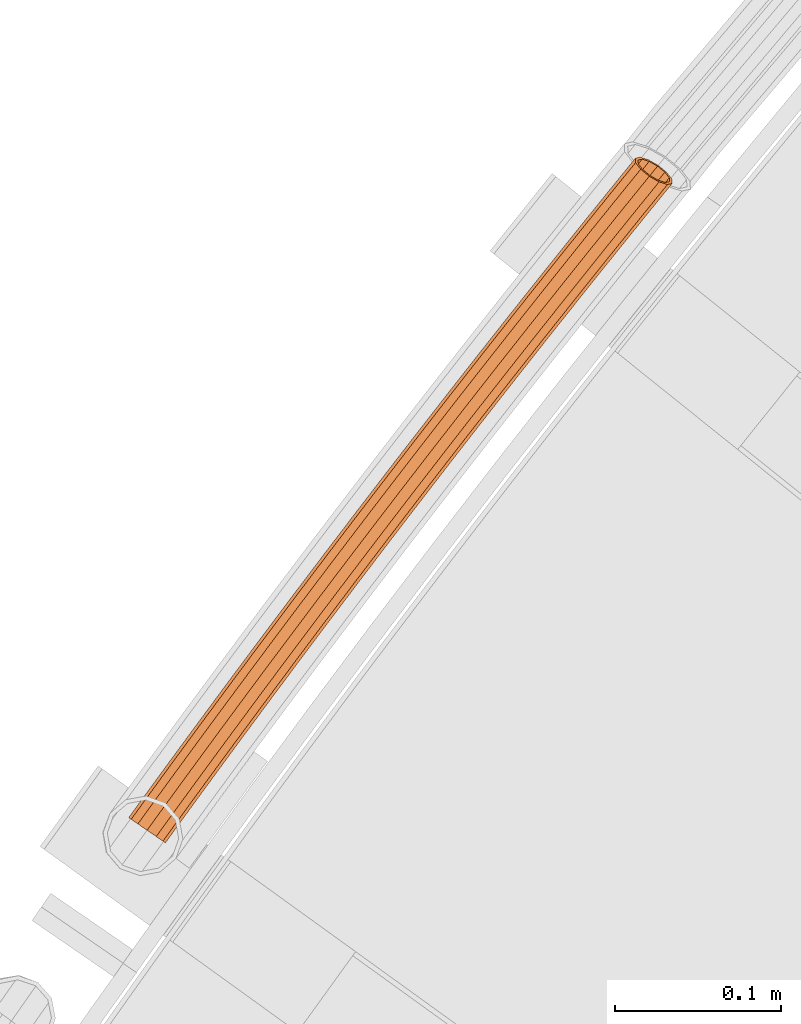
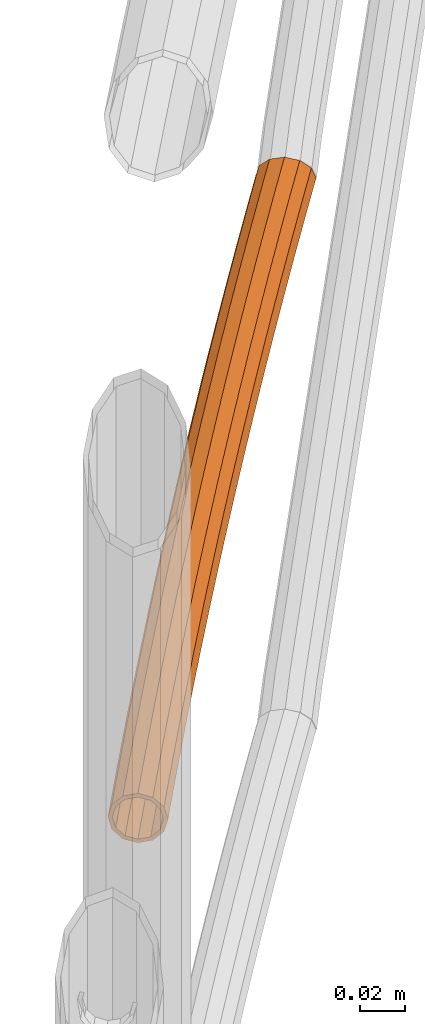
# One storey, part 66 of 126: 1 proxy.
"""IFC2X3 building model written with IfcOpenShell, lengths in millimetres."""

from ifc_helpers import new_model, si_unit, origin, origin_with_axes, place, context, project, spatial, faceted_brep, material, element, save


model = new_model("IFC2X3")

# Units and contexts
context_of_model_1 = context(None, 3, precision=0.1, world=origin())
context_of_model_2 = context(None, 3, precision=0.1, world=origin())
ifc_project = project(units=[si_unit("LENGTHUNIT", "METRE", prefix="MILLI"), si_unit("AREAUNIT", "SQUARE_METRE", prefix="CENTI"), si_unit("VOLUMEUNIT", "CUBIC_METRE", prefix="CENTI"), si_unit("MASSUNIT", "GRAM", prefix="KILO")], contexts=[context_of_model_1, context_of_model_2])

# Site, building, storey
site_placement = place(None, origin_with_axes())
site = spatial("IfcSite", under=ifc_project, at=site_placement, CompositionType="ELEMENT")
building_placement = place(site_placement, origin_with_axes())
building = spatial("IfcBuilding", under=site, at=building_placement, CompositionType="ELEMENT")
storey_placement = place(building_placement, origin_with_axes())
storey = spatial("IfcBuildingStorey", under=building, at=storey_placement, CompositionType="ELEMENT")

# Proxy
ifc_material = material(Name="S235JRG2")
proxy_placement = place(storey_placement, origin_with_axes())
element("IfcBuildingElementProxy", 1, at=proxy_placement, inside=storey, material=ifc_material, context=context_of_model_2, shape_type="Brep", body=[
    faceted_brep([(822.0705, 13221.789, 9066.8551), (823.5285, 13220.73, 9060.1301), (816.714, 13211.312, 9060.1301), (815.2283, 13212.333, 9066.8551), (827.5119, 13217.837, 9055.207), (820.7729, 13208.524, 9055.207), (832.9532, 13213.885, 9053.4051), (826.3174, 13204.714, 9053.4051), (838.3945, 13209.933, 9055.207), (831.862, 13200.905, 9055.207), (842.3779, 13207.04, 9060.1301), (835.9209, 13198.117, 9060.1301), (843.8359, 13205.981, 9066.8551), (837.4066, 13197.096, 9066.8551), (842.3779, 13207.04, 9073.5801), (835.9209, 13198.117, 9073.5801), (838.3945, 13209.933, 9078.5031), (831.862, 13200.905, 9078.5031), (832.9532, 13213.885, 9080.3051), (826.3174, 13204.714, 9080.3051), (827.5119, 13217.837, 9078.5031), (820.7729, 13208.524, 9078.5031), (823.5285, 13220.73, 9073.5801), (816.714, 13211.312, 9073.5801), (823.6888, 13220.613, 9066.8551), (824.93, 13219.712, 9072.5801), (818.142, 13210.331, 9072.5801), (816.8772, 13211.2, 9066.8551), (828.321, 13217.249, 9076.7711), (821.5973, 13207.957, 9076.7711), (832.9532, 13213.885, 9078.3051), (826.3174, 13204.714, 9078.3051), (837.5854, 13210.521, 9076.7711), (831.0375, 13201.472, 9076.7711), (840.9764, 13208.058, 9072.5801), (834.4929, 13199.098, 9072.5801), (842.2176, 13207.156, 9066.8551), (835.7576, 13198.229, 9066.8551), (840.9764, 13208.058, 9061.1301), (834.4929, 13199.098, 9061.1301), (837.5854, 13210.521, 9056.9391), (831.0375, 13201.472, 9056.9391), (832.9532, 13213.885, 9055.4051), (826.3174, 13204.714, 9055.4051), (828.321, 13217.249, 9056.9391), (821.5973, 13207.957, 9056.9391), (824.93, 13219.712, 9061.1301), (818.142, 13210.331, 9061.1301), (840.3243, 13246.83, 9066.8551), (841.7786, 13245.766, 9060.1301), (845.7518, 13242.859, 9055.207), (851.1793, 13238.888, 9053.4051), (856.6068, 13234.917, 9055.207), (860.58, 13232.01, 9060.1301), (862.0343, 13230.946, 9066.8551), (860.58, 13232.01, 9073.5801), (856.6068, 13234.917, 9078.5031), (851.1793, 13238.888, 9080.3051), (845.7518, 13242.859, 9078.5031), (841.7786, 13245.766, 9073.5801), (841.9384, 13245.649, 9066.8551), (843.1765, 13244.743, 9072.5801), (846.5589, 13242.269, 9076.7711), (851.1793, 13238.888, 9078.3051), (855.7997, 13235.508, 9076.7711), (859.1821, 13233.033, 9072.5801), (860.4202, 13232.127, 9066.8551), (859.1821, 13233.033, 9061.1301), (855.7997, 13235.508, 9056.9391), (851.1793, 13238.888, 9055.4051), (846.5589, 13242.269, 9056.9391), (843.1765, 13244.743, 9061.1301), (858.6653, 13271.807, 9066.8551), (860.1159, 13270.738, 9060.1301), (864.079, 13267.817, 9055.207), (869.4926, 13263.828, 9053.4051), (874.9062, 13259.838, 9055.207), (878.8692, 13256.917, 9060.1301), (880.3198, 13255.848, 9066.8551), (878.8692, 13256.917, 9073.5801), (874.9062, 13259.838, 9078.5031), (869.4926, 13263.828, 9080.3051), (864.079, 13267.817, 9078.5031), (860.1159, 13270.738, 9073.5801), (860.2753, 13270.621, 9066.8551), (861.5102, 13269.711, 9072.5801), (864.8839, 13267.224, 9076.7711), (869.4926, 13263.828, 9078.3051), (874.1012, 13260.431, 9076.7711), (877.4749, 13257.945, 9072.5801), (878.7098, 13257.035, 9066.8551), (877.4749, 13257.945, 9061.1301), (874.1012, 13260.431, 9056.9391), (869.4926, 13263.828, 9055.4051), (864.8839, 13267.224, 9056.9391), (861.5102, 13269.711, 9061.1301), (877.0935, 13296.721, 9066.8551), (878.5403, 13295.647, 9060.1301), (882.4931, 13292.712, 9055.207), (887.8928, 13288.703, 9053.4051), (893.2924, 13284.695, 9055.207), (897.2453, 13281.76, 9060.1301), (898.6921, 13280.686, 9066.8551), (897.2453, 13281.76, 9073.5801), (893.2924, 13284.695, 9078.5031), (887.8928, 13288.703, 9080.3051), (882.4931, 13292.712, 9078.5031), (878.5403, 13295.647, 9073.5801), (878.6993, 13295.528, 9066.8551), (879.931, 13294.614, 9072.5801), (883.296, 13292.116, 9076.7711), (887.8928, 13288.703, 9078.3051), (892.4895, 13285.291, 9076.7711), (895.8545, 13282.793, 9072.5801), (897.0862, 13281.878, 9066.8551), (895.8545, 13282.793, 9061.1301), (892.4895, 13285.291, 9056.9391), (887.8928, 13288.703, 9055.4051), (883.296, 13292.116, 9056.9391), (879.931, 13294.614, 9061.1301), (895.6084, 13321.569, 9066.8551), (897.0515, 13320.49, 9060.1301), (900.9941, 13317.542, 9055.207), (906.3797, 13313.514, 9053.4051), (911.7653, 13309.487, 9055.207), (915.7079, 13306.539, 9060.1301), (917.151, 13305.459, 9066.8551), (915.7079, 13306.539, 9073.5801), (911.7653, 13309.487, 9078.5031), (906.3797, 13313.514, 9080.3051), (900.9941, 13317.542, 9078.5031), (897.0515, 13320.49, 9073.5801), (897.2101, 13320.372, 9066.8551), (898.4386, 13319.453, 9072.5801), (901.7949, 13316.943, 9076.7711), (906.3797, 13313.514, 9078.3051), (910.9645, 13310.086, 9076.7711), (914.3208, 13307.576, 9072.5801), (915.5493, 13306.657, 9066.8551), (914.3208, 13307.576, 9061.1301), (910.9645, 13310.086, 9056.9391), (906.3797, 13313.514, 9055.4051), (901.7949, 13316.943, 9056.9391), (898.4386, 13319.453, 9061.1301), (914.21, 13346.353, 9066.8551), (915.6493, 13345.269, 9060.1301), (919.5816, 13342.307, 9055.207), (924.9531, 13338.261, 9053.4051), (930.3247, 13334.215, 9055.207), (934.2569, 13331.253, 9060.1301), (935.6962, 13330.168, 9066.8551), (934.2569, 13331.253, 9073.5801), (930.3247, 13334.215, 9078.5031), (924.9531, 13338.261, 9080.3051), (919.5816, 13342.307, 9078.5031), (915.6493, 13345.269, 9073.5801), (915.8075, 13345.15, 9066.8551), (917.0328, 13344.227, 9072.5801), (920.3803, 13341.706, 9076.7711), (924.9531, 13338.261, 9078.3051), (929.5259, 13334.816, 9076.7711), (932.8734, 13332.295, 9072.5801), (934.0987, 13331.372, 9066.8551), (932.8734, 13332.295, 9061.1301), (929.5259, 13334.816, 9056.9391), (924.9531, 13338.261, 9055.4051), (920.3803, 13341.706, 9056.9391), (917.0328, 13344.227, 9061.1301), (932.898, 13371.072, 9066.8551), (934.3336, 13369.983, 9060.1301), (938.2554, 13367.007, 9055.207), (943.6128, 13362.942, 9053.4051), (948.9702, 13358.877, 9055.207), (952.8921, 13355.902, 9060.1301), (954.3276, 13354.812, 9066.8551), (952.8921, 13355.902, 9073.5801), (948.9702, 13358.877, 9078.5031), (943.6128, 13362.942, 9080.3051), (938.2554, 13367.007, 9078.5031), (934.3336, 13369.983, 9073.5801), (934.4913, 13369.863, 9066.8551), (935.7134, 13368.936, 9072.5801), (939.0521, 13366.403, 9076.7711), (943.6128, 13362.942, 9078.3051), (948.1736, 13359.482, 9076.7711), (951.5122, 13356.949, 9072.5801), (952.7343, 13356.021, 9066.8551), (951.5122, 13356.949, 9061.1301), (948.1736, 13359.482, 9056.9391), (943.6128, 13362.942, 9055.4051), (939.0521, 13366.403, 9056.9391), (935.7134, 13368.936, 9061.1301), (951.6722, 13395.726, 9066.8551), (953.1039, 13394.632, 9060.1301), (957.0154, 13391.642, 9055.207), (962.3585, 13387.559, 9053.4051), (967.7017, 13383.475, 9055.207), (971.6132, 13380.485, 9060.1301), (973.0449, 13379.391, 9066.8551), (971.6132, 13380.485, 9073.5801), (967.7017, 13383.475, 9078.5031), (962.3585, 13387.559, 9080.3051), (957.0154, 13391.642, 9078.5031), (953.1039, 13394.632, 9073.5801), (953.2613, 13394.511, 9066.8551), (954.4801, 13393.58, 9072.5801), (957.8099, 13391.035, 9076.7711), (962.3585, 13387.559, 9078.3051), (966.9072, 13384.082, 9076.7711), (970.237, 13381.537, 9072.5801), (971.4558, 13380.606, 9066.8551), (970.237, 13381.537, 9061.1301), (966.9072, 13384.082, 9056.9391), (962.3585, 13387.559, 9055.4051), (957.8099, 13391.035, 9056.9391), (954.4801, 13393.58, 9061.1301), (970.5323, 13420.314, 9066.8551), (971.9602, 13419.215, 9060.1301), (975.8612, 13416.211, 9055.207), (981.1901, 13412.109, 9053.4051), (986.519, 13408.007, 9055.207), (990.42, 13405.004, 9060.1301), (991.8478, 13403.905, 9066.8551), (990.42, 13405.004, 9073.5801), (986.519, 13408.007, 9078.5031), (981.1901, 13412.109, 9080.3051), (975.8612, 13416.211, 9078.5031), (971.9602, 13419.215, 9073.5801), (972.1171, 13419.094, 9066.8551), (973.3327, 13418.158, 9072.5801), (976.6536, 13415.602, 9076.7711), (981.1901, 13412.109, 9078.3051), (985.7266, 13408.617, 9076.7711), (989.0475, 13406.06, 9072.5801), (990.263, 13405.125, 9066.8551), (989.0475, 13406.06, 9061.1301), (985.7266, 13408.617, 9056.9391), (981.1901, 13412.109, 9055.4051), (976.6536, 13415.602, 9056.9391), (973.3327, 13418.158, 9061.1301), (989.4782, 13444.836, 9066.8551), (990.9022, 13443.732, 9060.1301), (994.7927, 13440.715, 9055.207), (1000.1072, 13436.594, 9053.4051), (1005.4217, 13432.473, 9055.207), (1009.3122, 13429.456, 9060.1301), (1010.7362, 13428.352, 9066.8551), (1009.3122, 13429.456, 9073.5801), (1005.4217, 13432.473, 9078.5031), (1000.1072, 13436.594, 9080.3051), (994.7927, 13440.715, 9078.5031), (990.9022, 13443.732, 9073.5801), (991.0587, 13443.61, 9066.8551), (992.271, 13442.67, 9072.5801), (995.5829, 13440.102, 9076.7711), (1000.1072, 13436.594, 9078.3051), (1004.6315, 13433.086, 9076.7711), (1007.9434, 13430.518, 9072.5801), (1009.1557, 13429.578, 9066.8551), (1007.9434, 13430.518, 9061.1301), (1004.6315, 13433.086, 9056.9391), (1000.1072, 13436.594, 9055.4051), (995.5829, 13440.102, 9056.9391), (992.271, 13442.67, 9061.1301), (1008.5095, 13469.291, 9066.8551), (1009.9296, 13468.182, 9060.1301), (1013.8096, 13465.152, 9055.207), (1019.1097, 13461.012, 9053.4051), (1024.4098, 13456.873, 9055.207), (1028.2897, 13453.843, 9060.1301), (1029.7099, 13452.734, 9066.8551), (1028.2897, 13453.843, 9073.5801), (1024.4098, 13456.873, 9078.5031), (1019.1097, 13461.012, 9080.3051), (1013.8096, 13465.152, 9078.5031), (1009.9296, 13468.182, 9073.5801), (1010.0857, 13468.06, 9066.8551), (1011.2947, 13467.116, 9072.5801), (1014.5977, 13464.536, 9076.7711), (1019.1097, 13461.012, 9078.3051), (1023.6217, 13457.489, 9076.7711), (1026.9247, 13454.909, 9072.5801), (1028.1336, 13453.965, 9066.8551), (1026.9247, 13454.909, 9061.1301), (1023.6217, 13457.489, 9056.9391), (1019.1097, 13461.012, 9055.4051), (1014.5977, 13464.536, 9056.9391), (1011.2947, 13467.116, 9061.1301), (1027.626, 13493.68, 9066.8551), (1029.0423, 13492.566, 9060.1301), (1032.9117, 13489.522, 9055.207), (1038.1973, 13485.365, 9053.4051), (1043.4829, 13481.207, 9055.207), (1047.3522, 13478.163, 9060.1301), (1048.7685, 13477.049, 9066.8551), (1047.3522, 13478.163, 9073.5801), (1043.4829, 13481.207, 9078.5031), (1038.1973, 13485.365, 9080.3051), (1032.9117, 13489.522, 9078.5031), (1029.0423, 13492.566, 9073.5801), (1029.198, 13492.444, 9066.8551), (1030.4036, 13491.495, 9072.5801), (1033.6976, 13488.904, 9076.7711), (1038.1973, 13485.365, 9078.3051), (1042.6969, 13481.825, 9076.7711), (1045.9909, 13479.234, 9072.5801), (1047.1966, 13478.285, 9066.8551), (1045.9909, 13479.234, 9061.1301), (1042.6969, 13481.825, 9056.9391), (1038.1973, 13485.365, 9055.4051), (1033.6976, 13488.904, 9056.9391), (1030.4036, 13491.495, 9061.1301), (1046.8276, 13518.002, 9066.8551), (1048.24, 13516.883, 9060.1301), (1052.0987, 13513.826, 9055.207), (1057.3698, 13509.65, 9053.4051), (1062.6408, 13505.474, 9055.207), (1066.4995, 13502.416, 9060.1301), (1067.9119, 13501.297, 9066.8551), (1066.4995, 13502.416, 9073.5801), (1062.6408, 13505.474, 9078.5031), (1057.3698, 13509.65, 9080.3051), (1052.0987, 13513.826, 9078.5031), (1048.24, 13516.883, 9073.5801), (1048.3952, 13516.76, 9066.8551), (1049.5976, 13515.808, 9072.5801), (1052.8825, 13513.205, 9076.7711), (1057.3698, 13509.65, 9078.3051), (1061.857, 13506.094, 9076.7711), (1065.1419, 13503.492, 9072.5801), (1066.3443, 13502.539, 9066.8551), (1065.1419, 13503.492, 9061.1301), (1061.857, 13506.094, 9056.9391), (1057.3698, 13509.65, 9055.4051), (1052.8825, 13513.205, 9056.9391), (1049.5976, 13515.808, 9061.1301), (1066.114, 13542.257, 9066.8551), (1067.5224, 13541.133, 9060.1301), (1071.3704, 13538.063, 9055.207), (1076.6269, 13533.868, 9053.4051), (1081.8834, 13529.673, 9055.207), (1085.7314, 13526.603, 9060.1301), (1087.1398, 13525.479, 9066.8551), (1085.7314, 13526.603, 9073.5801), (1081.8834, 13529.673, 9078.5031), (1076.6269, 13533.868, 9080.3051), (1071.3704, 13538.063, 9078.5031), (1067.5224, 13541.133, 9073.5801), (1067.6772, 13541.01, 9066.8551), (1068.8763, 13540.053, 9072.5801), (1072.1521, 13537.439, 9076.7711), (1076.6269, 13533.868, 9078.3051), (1081.1017, 13530.297, 9076.7711), (1084.3775, 13527.683, 9072.5801), (1085.5766, 13526.726, 9066.8551), (1084.3775, 13527.683, 9061.1301), (1081.1017, 13530.297, 9056.9391), (1076.6269, 13533.868, 9055.4051), (1072.1521, 13537.439, 9056.9391), (1068.8763, 13540.053, 9061.1301), (1085.4849, 13566.445, 9066.8551), (1086.8894, 13565.316, 9060.1301), (1090.7267, 13562.232, 9055.207), (1095.9685, 13558.019, 9053.4051), (1101.2103, 13553.806, 9055.207), (1105.0475, 13550.722, 9060.1301), (1106.452, 13549.593, 9066.8551), (1105.0475, 13550.722, 9073.5801), (1101.2103, 13553.806, 9078.5031), (1095.9685, 13558.019, 9080.3051), (1090.7267, 13562.232, 9078.5031), (1086.8894, 13565.316, 9073.5801), (1087.0438, 13565.192, 9066.8551), (1088.2395, 13564.231, 9072.5801), (1091.5061, 13561.605, 9076.7711), (1095.9685, 13558.019, 9078.3051), (1100.4308, 13554.432, 9076.7711), (1103.6975, 13551.807, 9072.5801), (1104.8932, 13550.846, 9066.8551), (1103.6975, 13551.807, 9061.1301), (1100.4308, 13554.432, 9056.9391), (1095.9685, 13558.019, 9055.4051), (1091.5061, 13561.605, 9056.9391), (1088.2395, 13564.231, 9061.1301), (1104.9401, 13590.565, 9066.8551), (1106.3407, 13589.431, 9060.1301), (1110.1672, 13586.333, 9055.207), (1115.3942, 13582.102, 9053.4051), (1120.6213, 13577.871, 9055.207), (1124.4477, 13574.773, 9060.1301), (1125.8483, 13573.639, 9066.8551), (1124.4477, 13574.773, 9073.5801), (1120.6213, 13577.871, 9078.5031), (1115.3942, 13582.102, 9080.3051), (1110.1672, 13586.333, 9078.5031), (1106.3407, 13589.431, 9073.5801), (1106.4946, 13589.306, 9066.8551), (1107.6869, 13588.341, 9072.5801), (1110.9444, 13585.704, 9076.7711), (1115.3942, 13582.102, 9078.3051), (1119.844, 13578.5, 9076.7711), (1123.1015, 13575.863, 9072.5801), (1124.2938, 13574.898, 9066.8551), (1123.1015, 13575.863, 9061.1301), (1119.844, 13578.5, 9056.9391), (1115.3942, 13582.102, 9055.4051), (1110.9444, 13585.704, 9056.9391), (1107.6869, 13588.341, 9061.1301), (1121.3614, 13610.778, 9066.8551), (1124.1969, 13611.411, 9060.1301), (1129.2527, 13609.826, 9055.207), (1132.9183, 13607.736, 9054.0915), (1134.9039, 13606.117, 9053.4051), (1140.1162, 13601.868, 9055.207), (1141.4659, 13600.767, 9056.9486), (1143.4601, 13598.176, 9060.1301), (1143.6047, 13595.496, 9066.8551), (1140.7691, 13594.864, 9073.5801), (1135.7133, 13596.448, 9078.5031), (1129.792, 13599.825, 9080.3051), (1124.5917, 13604.089, 9078.5031), (1121.5059, 13608.098, 9073.5801), (1123.0151, 13609.642, 9066.8551), (1123.1381, 13607.361, 9072.5801), (1125.7651, 13603.948, 9076.7711), (1130.1921, 13600.317, 9078.3051), (1135.233, 13597.443, 9076.7711), (1139.537, 13596.094, 9072.5801), (1141.9509, 13596.633, 9066.8551), (1141.8279, 13598.914, 9061.1301), (1139.2009, 13602.327, 9056.9391), (1134.7739, 13605.957, 9055.4051), (1129.733, 13608.832, 9056.9391), (1125.429, 13610.181, 9061.1301), (1135.1753, 13606.449, 9053.4051), (1140.3755, 13602.185, 9055.207)], [[[0, 1, 2, 3]], [[1, 4, 5, 2]], [[4, 6, 7, 5]], [[6, 8, 9, 7]], [[8, 10, 11, 9]], [[10, 12, 13, 11]], [[12, 14, 15, 13]], [[14, 16, 17, 15]], [[16, 18, 19, 17]], [[18, 20, 21, 19]], [[20, 22, 23, 21]], [[0, 3, 23, 22]], [[24, 25, 26, 27]], [[25, 28, 29, 26]], [[28, 30, 31, 29]], [[30, 32, 33, 31]], [[32, 34, 35, 33]], [[34, 36, 37, 35]], [[36, 38, 39, 37]], [[38, 40, 41, 39]], [[40, 42, 43, 41]], [[42, 44, 45, 43]], [[44, 46, 47, 45]], [[24, 27, 47, 46]], [[0, 48, 49, 1]], [[1, 49, 50, 4]], [[4, 50, 51, 6]], [[6, 51, 52, 8]], [[8, 52, 53, 10]], [[10, 53, 54, 12]], [[12, 54, 55, 14]], [[14, 55, 56, 16]], [[16, 56, 57, 18]], [[18, 57, 58, 20]], [[20, 58, 59, 22]], [[22, 59, 48, 0]], [[24, 60, 61, 25]], [[25, 61, 62, 28]], [[28, 62, 63, 30]], [[30, 63, 64, 32]], [[32, 64, 65, 34]], [[34, 65, 66, 36]], [[36, 66, 67, 38]], [[38, 67, 68, 40]], [[40, 68, 69, 42]], [[42, 69, 70, 44]], [[44, 70, 71, 46]], [[46, 71, 60, 24]], [[48, 72, 73, 49]], [[49, 73, 74, 50]], [[50, 74, 75, 51]], [[51, 75, 76, 52]], [[52, 76, 77, 53]], [[53, 77, 78, 54]], [[54, 78, 79, 55]], [[55, 79, 80, 56]], [[56, 80, 81, 57]], [[57, 81, 82, 58]], [[58, 82, 83, 59]], [[59, 83, 72, 48]], [[60, 84, 85, 61]], [[61, 85, 86, 62]], [[62, 86, 87, 63]], [[63, 87, 88, 64]], [[64, 88, 89, 65]], [[65, 89, 90, 66]], [[66, 90, 91, 67]], [[67, 91, 92, 68]], [[68, 92, 93, 69]], [[69, 93, 94, 70]], [[70, 94, 95, 71]], [[71, 95, 84, 60]], [[72, 96, 97, 73]], [[73, 97, 98, 74]], [[74, 98, 99, 75]], [[75, 99, 100, 76]], [[76, 100, 101, 77]], [[77, 101, 102, 78]], [[78, 102, 103, 79]], [[79, 103, 104, 80]], [[80, 104, 105, 81]], [[81, 105, 106, 82]], [[82, 106, 107, 83]], [[83, 107, 96, 72]], [[84, 108, 109, 85]], [[85, 109, 110, 86]], [[86, 110, 111, 87]], [[87, 111, 112, 88]], [[88, 112, 113, 89]], [[89, 113, 114, 90]], [[90, 114, 115, 91]], [[91, 115, 116, 92]], [[92, 116, 117, 93]], [[93, 117, 118, 94]], [[94, 118, 119, 95]], [[95, 119, 108, 84]], [[96, 120, 121, 97]], [[97, 121, 122, 98]], [[98, 122, 123, 99]], [[99, 123, 124, 100]], [[100, 124, 125, 101]], [[101, 125, 126, 102]], [[102, 126, 127, 103]], [[103, 127, 128, 104]], [[104, 128, 129, 105]], [[105, 129, 130, 106]], [[106, 130, 131, 107]], [[107, 131, 120, 96]], [[108, 132, 133, 109]], [[109, 133, 134, 110]], [[110, 134, 135, 111]], [[111, 135, 136, 112]], [[112, 136, 137, 113]], [[113, 137, 138, 114]], [[114, 138, 139, 115]], [[115, 139, 140, 116]], [[116, 140, 141, 117]], [[117, 141, 142, 118]], [[118, 142, 143, 119]], [[119, 143, 132, 108]], [[120, 144, 145, 121]], [[121, 145, 146, 122]], [[122, 146, 147, 123]], [[123, 147, 148, 124]], [[124, 148, 149, 125]], [[125, 149, 150, 126]], [[126, 150, 151, 127]], [[127, 151, 152, 128]], [[128, 152, 153, 129]], [[129, 153, 154, 130]], [[130, 154, 155, 131]], [[131, 155, 144, 120]], [[132, 156, 157, 133]], [[133, 157, 158, 134]], [[134, 158, 159, 135]], [[135, 159, 160, 136]], [[136, 160, 161, 137]], [[137, 161, 162, 138]], [[138, 162, 163, 139]], [[139, 163, 164, 140]], [[140, 164, 165, 141]], [[141, 165, 166, 142]], [[142, 166, 167, 143]], [[143, 167, 156, 132]], [[144, 168, 169, 145]], [[145, 169, 170, 146]], [[146, 170, 171, 147]], [[147, 171, 172, 148]], [[148, 172, 173, 149]], [[149, 173, 174, 150]], [[150, 174, 175, 151]], [[151, 175, 176, 152]], [[152, 176, 177, 153]], [[153, 177, 178, 154]], [[154, 178, 179, 155]], [[155, 179, 168, 144]], [[156, 180, 181, 157]], [[157, 181, 182, 158]], [[158, 182, 183, 159]], [[159, 183, 184, 160]], [[160, 184, 185, 161]], [[161, 185, 186, 162]], [[162, 186, 187, 163]], [[163, 187, 188, 164]], [[164, 188, 189, 165]], [[165, 189, 190, 166]], [[166, 190, 191, 167]], [[167, 191, 180, 156]], [[168, 192, 193, 169]], [[169, 193, 194, 170]], [[170, 194, 195, 171]], [[171, 195, 196, 172]], [[172, 196, 197, 173]], [[173, 197, 198, 174]], [[174, 198, 199, 175]], [[175, 199, 200, 176]], [[176, 200, 201, 177]], [[177, 201, 202, 178]], [[178, 202, 203, 179]], [[179, 203, 192, 168]], [[180, 204, 205, 181]], [[181, 205, 206, 182]], [[182, 206, 207, 183]], [[183, 207, 208, 184]], [[184, 208, 209, 185]], [[185, 209, 210, 186]], [[186, 210, 211, 187]], [[187, 211, 212, 188]], [[188, 212, 213, 189]], [[189, 213, 214, 190]], [[190, 214, 215, 191]], [[191, 215, 204, 180]], [[192, 216, 217, 193]], [[193, 217, 218, 194]], [[194, 218, 219, 195]], [[195, 219, 220, 196]], [[196, 220, 221, 197]], [[197, 221, 222, 198]], [[198, 222, 223, 199]], [[199, 223, 224, 200]], [[200, 224, 225, 201]], [[201, 225, 226, 202]], [[202, 226, 227, 203]], [[203, 227, 216, 192]], [[204, 228, 229, 205]], [[205, 229, 230, 206]], [[206, 230, 231, 207]], [[207, 231, 232, 208]], [[208, 232, 233, 209]], [[209, 233, 234, 210]], [[210, 234, 235, 211]], [[211, 235, 236, 212]], [[212, 236, 237, 213]], [[213, 237, 238, 214]], [[214, 238, 239, 215]], [[215, 239, 228, 204]], [[216, 240, 241, 217]], [[217, 241, 242, 218]], [[218, 242, 243, 219]], [[219, 243, 244, 220]], [[220, 244, 245, 221]], [[221, 245, 246, 222]], [[222, 246, 247, 223]], [[223, 247, 248, 224]], [[224, 248, 249, 225]], [[225, 249, 250, 226]], [[226, 250, 251, 227]], [[227, 251, 240, 216]], [[228, 252, 253, 229]], [[229, 253, 254, 230]], [[230, 254, 255, 231]], [[231, 255, 256, 232]], [[232, 256, 257, 233]], [[233, 257, 258, 234]], [[234, 258, 259, 235]], [[235, 259, 260, 236]], [[236, 260, 261, 237]], [[237, 261, 262, 238]], [[238, 262, 263, 239]], [[239, 263, 252, 228]], [[240, 264, 265, 241]], [[241, 265, 266, 242]], [[242, 266, 267, 243]], [[243, 267, 268, 244]], [[244, 268, 269, 245]], [[245, 269, 270, 246]], [[246, 270, 271, 247]], [[247, 271, 272, 248]], [[248, 272, 273, 249]], [[249, 273, 274, 250]], [[250, 274, 275, 251]], [[251, 275, 264, 240]], [[252, 276, 277, 253]], [[253, 277, 278, 254]], [[254, 278, 279, 255]], [[255, 279, 280, 256]], [[256, 280, 281, 257]], [[257, 281, 282, 258]], [[258, 282, 283, 259]], [[259, 283, 284, 260]], [[260, 284, 285, 261]], [[261, 285, 286, 262]], [[262, 286, 287, 263]], [[263, 287, 276, 252]], [[264, 288, 289, 265]], [[265, 289, 290, 266]], [[266, 290, 291, 267]], [[267, 291, 292, 268]], [[268, 292, 293, 269]], [[269, 293, 294, 270]], [[270, 294, 295, 271]], [[271, 295, 296, 272]], [[272, 296, 297, 273]], [[273, 297, 298, 274]], [[274, 298, 299, 275]], [[275, 299, 288, 264]], [[276, 300, 301, 277]], [[277, 301, 302, 278]], [[278, 302, 303, 279]], [[279, 303, 304, 280]], [[280, 304, 305, 281]], [[281, 305, 306, 282]], [[282, 306, 307, 283]], [[283, 307, 308, 284]], [[284, 308, 309, 285]], [[285, 309, 310, 286]], [[286, 310, 311, 287]], [[287, 311, 300, 276]], [[288, 312, 313, 289]], [[289, 313, 314, 290]], [[290, 314, 315, 291]], [[291, 315, 316, 292]], [[292, 316, 317, 293]], [[293, 317, 318, 294]], [[294, 318, 319, 295]], [[295, 319, 320, 296]], [[296, 320, 321, 297]], [[297, 321, 322, 298]], [[298, 322, 323, 299]], [[299, 323, 312, 288]], [[300, 324, 325, 301]], [[301, 325, 326, 302]], [[302, 326, 327, 303]], [[303, 327, 328, 304]], [[304, 328, 329, 305]], [[305, 329, 330, 306]], [[306, 330, 331, 307]], [[307, 331, 332, 308]], [[308, 332, 333, 309]], [[309, 333, 334, 310]], [[310, 334, 335, 311]], [[311, 335, 324, 300]], [[312, 336, 337, 313]], [[313, 337, 338, 314]], [[314, 338, 339, 315]], [[315, 339, 340, 316]], [[316, 340, 341, 317]], [[317, 341, 342, 318]], [[318, 342, 343, 319]], [[319, 343, 344, 320]], [[320, 344, 345, 321]], [[321, 345, 346, 322]], [[322, 346, 347, 323]], [[323, 347, 336, 312]], [[324, 348, 349, 325]], [[325, 349, 350, 326]], [[326, 350, 351, 327]], [[327, 351, 352, 328]], [[328, 352, 353, 329]], [[329, 353, 354, 330]], [[330, 354, 355, 331]], [[331, 355, 356, 332]], [[332, 356, 357, 333]], [[333, 357, 358, 334]], [[334, 358, 359, 335]], [[335, 359, 348, 324]], [[336, 360, 361, 337]], [[337, 361, 362, 338]], [[338, 362, 363, 339]], [[339, 363, 364, 340]], [[340, 364, 365, 341]], [[341, 365, 366, 342]], [[342, 366, 367, 343]], [[343, 367, 368, 344]], [[344, 368, 369, 345]], [[345, 369, 370, 346]], [[346, 370, 371, 347]], [[347, 371, 360, 336]], [[348, 372, 373, 349]], [[349, 373, 374, 350]], [[350, 374, 375, 351]], [[351, 375, 376, 352]], [[352, 376, 377, 353]], [[353, 377, 378, 354]], [[354, 378, 379, 355]], [[355, 379, 380, 356]], [[356, 380, 381, 357]], [[357, 381, 382, 358]], [[358, 382, 383, 359]], [[359, 383, 372, 348]], [[360, 384, 385, 361]], [[361, 385, 386, 362]], [[362, 386, 387, 363]], [[363, 387, 388, 364]], [[364, 388, 389, 365]], [[365, 389, 390, 366]], [[366, 390, 391, 367]], [[367, 391, 392, 368]], [[368, 392, 393, 369]], [[369, 393, 394, 370]], [[370, 394, 395, 371]], [[371, 395, 384, 360]], [[372, 396, 397, 373]], [[373, 397, 398, 374]], [[374, 398, 399, 375]], [[375, 399, 400, 376]], [[376, 400, 401, 377]], [[377, 401, 402, 378]], [[378, 402, 403, 379]], [[379, 403, 404, 380]], [[380, 404, 405, 381]], [[381, 405, 406, 382]], [[382, 406, 407, 383]], [[383, 407, 396, 372]], [[384, 408, 409, 385]], [[385, 409, 410, 386]], [[386, 410, 411, 412, 387]], [[387, 412, 413, 388]], [[388, 413, 414, 415, 389]], [[389, 415, 416, 390]], [[390, 416, 417, 391]], [[391, 417, 418, 392]], [[392, 418, 419, 393]], [[393, 419, 420, 394]], [[394, 420, 421, 395]], [[384, 395, 421, 408]], [[396, 422, 423, 397]], [[397, 423, 424, 398]], [[398, 424, 425, 399]], [[399, 425, 426, 400]], [[400, 426, 427, 401]], [[401, 427, 428, 402]], [[402, 428, 429, 403]], [[403, 429, 430, 404]], [[404, 430, 431, 405]], [[405, 431, 432, 406]], [[406, 432, 433, 407]], [[396, 407, 433, 422]], [[411, 434, 412]], [[412, 434, 435, 413]], [[413, 435, 414]], [[7, 9, 11, 13, 15, 17, 19, 21, 23, 3, 2, 5], [26, 29, 31, 33, 35, 37, 39, 41, 43, 45, 47, 27]], [[408, 421, 420, 419, 418, 417, 416, 415, 414, 435, 434, 411, 410, 409], [422, 433, 432, 431, 430, 429, 428, 427, 426, 425, 424, 423]]]),
])

save(model, "model.ifc")
